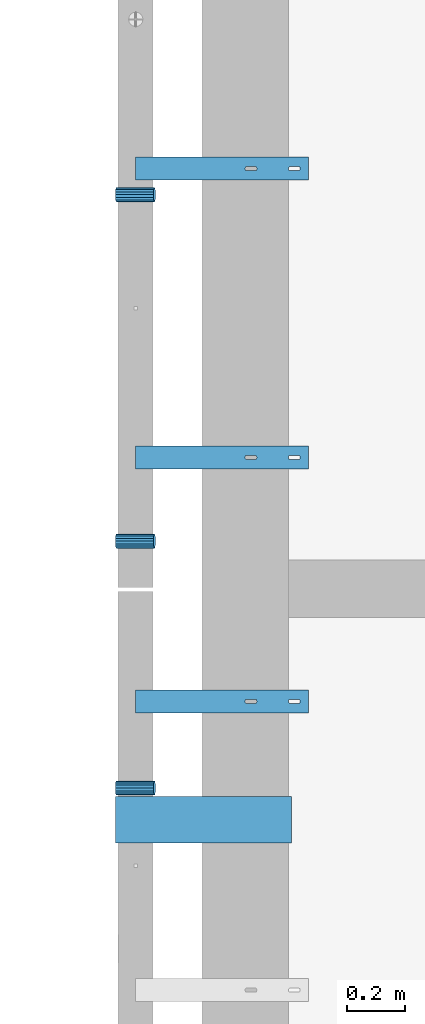
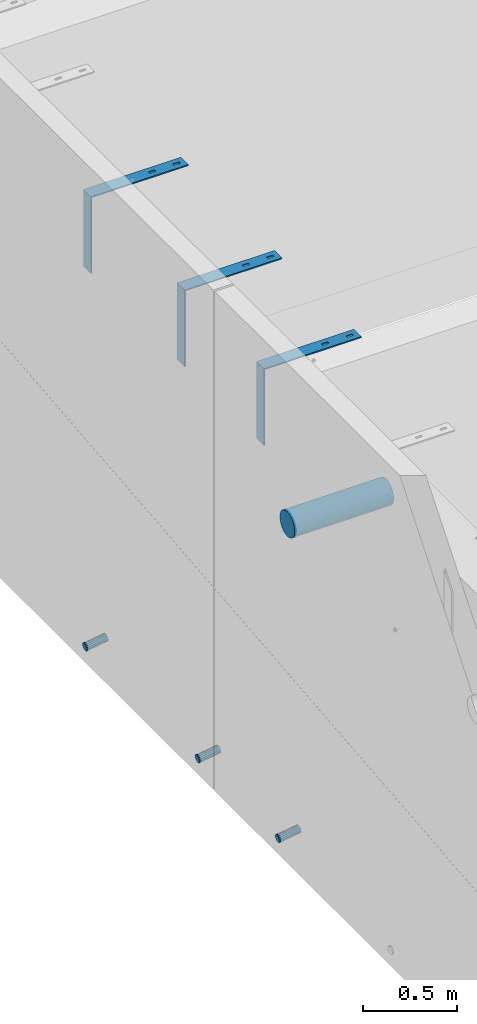
# One storey, part 98 of 264: 7 beams, 9 elements without a shape of their own.
"""IFC2X3 building model written with IfcOpenShell, lengths in millimetres."""

from ifc_helpers import new_model, si_unit, frame, origin_with_axes, place, context, subcontext, project, spatial, faceted_brep, material, type_object, element, aggregate, save


model = new_model("IFC2X3")

# Units and contexts
model_context = context("Model", 3, precision=1e-05, world=origin_with_axes())
body_context = subcontext(model_context, "Body", "Model", "MODEL_VIEW")
ifc_project = project(units=[si_unit("LENGTHUNIT", "METRE", prefix="MILLI"), si_unit("AREAUNIT", "SQUARE_METRE"), si_unit("VOLUMEUNIT", "CUBIC_METRE"), si_unit("MASSUNIT", "GRAM", prefix="KILO"), si_unit("TIMEUNIT", "SECOND"), si_unit("PLANEANGLEUNIT", "RADIAN"), si_unit("SOLIDANGLEUNIT", "STERADIAN"), si_unit("THERMODYNAMICTEMPERATUREUNIT", "DEGREE_CELSIUS"), si_unit("LUMINOUSINTENSITYUNIT", "LUMEN")], contexts=[model_context])

# Site, building, storey
site_placement = place(None, origin_with_axes())
site = spatial("IfcSite", under=ifc_project, at=site_placement, CompositionType="ELEMENT")
building_placement = place(site_placement, origin_with_axes())
building = spatial("IfcBuilding", under=site, at=building_placement, CompositionType="ELEMENT")
storey_placement = place(building_placement, origin_with_axes())
storey = spatial("IfcBuildingStorey", under=building, at=storey_placement, Name="K", CompositionType="ELEMENT", Elevation=0.0)

# Assemblies, beams
assembly_1_placement = place(storey_placement, origin_with_axes())
assembly_1 = element("IfcElementAssembly", 1, at=assembly_1_placement, inside=storey, AssemblyPlace="NOTDEFINED", PredefinedType="REINFORCEMENT_UNIT")
assembly_2_placement = place(assembly_1_placement, origin_with_axes())
assembly_2 = element("IfcElementAssembly", 2, at=assembly_2_placement, Name="Steel Assembly", AssemblyPlace="NOTDEFINED", PredefinedType="NOTDEFINED")
ifc_material_1 = material()
beam_type_1 = type_object("IfcBeamType", Name="D50", PredefinedType="NOTDEFINED")
beam_1_placement = place(assembly_2_placement, frame((7685.611109453, 18344.9999997536, 78614.7172983598), z_axis=(0.0, -1.0, 0.0), x_axis=(-0.988691934499859, -5.59999884149448e-08, -0.149960857075848)))
beam_1 = element("IfcBeam", 3, at=beam_1_placement, type_object=beam_type_1, material=ifc_material_1, ObjectType="D50", context=body_context, shape_type="Brep", body=[
    faceted_brep([(0.0, -25.0, 0.0), (-3.63797880709171e-12, -23.0969883127837, -9.56708580912891), (133.368135763521, -23.0969883127691, -9.56708580912709), (133.368135766923, -24.9999999999854, 1.81898940354586e-12), (-3.63797880709171e-12, -17.6776695296576, -17.6776695296649), (133.36813576064, -17.6776695296576, -17.677669529663), (-1.09139364212751e-11, -9.56708580913255, -23.0969883127837), (133.368135758712, -9.567085809118, -23.0969883127818), (-1.09139364212751e-11, 0.0, -25.0), (133.368135758034, 0.0, -25.0), (-1.09139364212751e-11, 9.56708580913255, -23.0969883127837), (133.36813575871, 9.56708580913255, -23.0969883127837), (-3.63797880709171e-12, 17.6776695296576, -17.6776695296649), (133.36813576064, 17.6776695296721, -17.677669529663), (-3.63797880709171e-12, 23.0969883127837, -9.56708580912891), (133.36813576352, 23.0969883127982, -9.56708580912709), (0.0, 25.0, 0.0), (133.368135766925, 25.0000000000146, -1.81898940354586e-12), (7.27595761418343e-12, 23.0969883127837, 9.56708580912891), (133.368135770323, 23.0969883127837, 9.56708580912709), (7.27595761418343e-12, 17.6776695296576, 17.6776695296649), (133.368135773204, 17.6776695296721, 17.6776695296649), (1.45519152283669e-11, 9.56708580913255, 23.0969883127837), (133.368135775132, 9.5670858091471, 23.0969883127837), (1.09139364212751e-11, 0.0, 25.0), (133.368135775807, 1.45519152283669e-11, 25.0), (1.45519152283669e-11, -9.56708580913255, 23.0969883127837), (133.368135775134, -9.56708580910345, 23.0969883127837), (7.27595761418343e-12, -17.6776695296576, 17.6776695296649), (133.368135773204, -17.6776695296721, 17.6776695296649), (7.27595761418343e-12, -23.0969883127837, 9.56708580912891), (133.368135770321, -23.0969883127691, 9.56708580912709)], [[[0, 1, 2, 3]], [[1, 4, 5, 2]], [[4, 6, 7, 5]], [[6, 8, 9, 7]], [[8, 10, 11, 9]], [[10, 12, 13, 11]], [[12, 14, 15, 13]], [[14, 16, 17, 15]], [[16, 18, 19, 17]], [[18, 20, 21, 19]], [[20, 22, 23, 21]], [[22, 24, 25, 23]], [[24, 26, 27, 25]], [[26, 28, 29, 27]], [[28, 30, 31, 29]], [[30, 0, 3, 31]], [[5, 7, 9, 11, 13, 15, 17, 19, 21, 23, 25, 27, 29, 31, 3, 2]], [[30, 28, 26, 24, 22, 20, 18, 16, 14, 12, 10, 8, 6, 4, 1, 0]]]),
])
aggregate(assembly_2, [beam_1])
assembly_3_placement = place(assembly_1_placement, origin_with_axes())
assembly_3 = element("IfcElementAssembly", 4, at=assembly_3_placement, Name="Steel Assembly", AssemblyPlace="NOTDEFINED", PredefinedType="NOTDEFINED")
beam_2_placement = place(assembly_3_placement, frame((7685.611109453, 17144.9999997536, 78614.7172983598), z_axis=(0.0, -1.0, 0.0), x_axis=(-0.988691934499859, -5.59999884149448e-08, -0.149960857075848)))
beam_2 = element("IfcBeam", 5, at=beam_2_placement, type_object=beam_type_1, material=ifc_material_1, ObjectType="D50", context=body_context, shape_type="Brep", body=[
    faceted_brep([(0.0, -25.0, 0.0), (-3.63797880709171e-12, -23.0969883127837, -9.56708580912891), (133.368135763521, -23.0969883127691, -9.56708580912709), (133.368135766923, -24.9999999999854, 1.81898940354586e-12), (-3.63797880709171e-12, -17.6776695296576, -17.6776695296649), (133.36813576064, -17.6776695296576, -17.677669529663), (-1.09139364212751e-11, -9.56708580913255, -23.0969883127837), (133.368135758712, -9.567085809118, -23.0969883127818), (-1.09139364212751e-11, 0.0, -25.0), (133.368135758034, 0.0, -25.0), (-1.09139364212751e-11, 9.56708580913255, -23.0969883127837), (133.36813575871, 9.56708580913255, -23.0969883127837), (-3.63797880709171e-12, 17.6776695296576, -17.6776695296649), (133.36813576064, 17.6776695296721, -17.677669529663), (-3.63797880709171e-12, 23.0969883127837, -9.56708580912891), (133.36813576352, 23.0969883127982, -9.56708580912709), (0.0, 25.0, 0.0), (133.368135766925, 25.0000000000146, -1.81898940354586e-12), (7.27595761418343e-12, 23.0969883127837, 9.56708580912891), (133.368135770323, 23.0969883127837, 9.56708580912709), (7.27595761418343e-12, 17.6776695296576, 17.6776695296649), (133.368135773204, 17.6776695296721, 17.6776695296649), (1.45519152283669e-11, 9.56708580913255, 23.0969883127837), (133.368135775132, 9.5670858091471, 23.0969883127837), (1.09139364212751e-11, 0.0, 25.0), (133.368135775807, 1.45519152283669e-11, 25.0), (1.45519152283669e-11, -9.56708580913255, 23.0969883127837), (133.368135775134, -9.56708580910345, 23.0969883127837), (7.27595761418343e-12, -17.6776695296576, 17.6776695296649), (133.368135773204, -17.6776695296721, 17.6776695296649), (7.27595761418343e-12, -23.0969883127837, 9.56708580912891), (133.368135770321, -23.0969883127691, 9.56708580912709)], [[[0, 1, 2, 3]], [[1, 4, 5, 2]], [[4, 6, 7, 5]], [[6, 8, 9, 7]], [[8, 10, 11, 9]], [[10, 12, 13, 11]], [[12, 14, 15, 13]], [[14, 16, 17, 15]], [[16, 18, 19, 17]], [[18, 20, 21, 19]], [[20, 22, 23, 21]], [[22, 24, 25, 23]], [[24, 26, 27, 25]], [[26, 28, 29, 27]], [[28, 30, 31, 29]], [[30, 0, 3, 31]], [[5, 7, 9, 11, 13, 15, 17, 19, 21, 23, 25, 27, 29, 31, 3, 2]], [[30, 28, 26, 24, 22, 20, 18, 16, 14, 12, 10, 8, 6, 4, 1, 0]]]),
])
aggregate(assembly_3, [beam_2])

# Assemblies, beam
assembly_4_placement = place(storey_placement, origin_with_axes())
assembly_4 = element("IfcElementAssembly", 6, at=assembly_4_placement, inside=storey, AssemblyPlace="NOTDEFINED", PredefinedType="REINFORCEMENT_UNIT")
assembly_5_placement = place(assembly_4_placement, origin_with_axes())
assembly_5 = element("IfcElementAssembly", 7, at=assembly_5_placement, Name="Steel Assembly", AssemblyPlace="NOTDEFINED", PredefinedType="NOTDEFINED")
beam_3_placement = place(assembly_5_placement, frame((7685.611109453, 16289.9999997536, 78614.7172983598), z_axis=(0.0, -1.0, 0.0), x_axis=(-0.988691934499859, -5.59999884149448e-08, -0.149960857075848)))
beam_3 = element("IfcBeam", 8, at=beam_3_placement, type_object=beam_type_1, material=ifc_material_1, ObjectType="D50", context=body_context, shape_type="Brep", body=[
    faceted_brep([(0.0, -25.0, 0.0), (-3.63797880709171e-12, -23.0969883127837, -9.56708580912891), (133.368135763521, -23.0969883127691, -9.56708580912709), (133.368135766923, -24.9999999999854, 1.81898940354586e-12), (-3.63797880709171e-12, -17.6776695296576, -17.6776695296649), (133.36813576064, -17.6776695296576, -17.677669529663), (-1.09139364212751e-11, -9.56708580913255, -23.0969883127837), (133.368135758712, -9.567085809118, -23.0969883127818), (-1.09139364212751e-11, 0.0, -25.0), (133.368135758034, 0.0, -25.0), (-1.09139364212751e-11, 9.56708580913255, -23.0969883127837), (133.36813575871, 9.56708580913255, -23.0969883127837), (-3.63797880709171e-12, 17.6776695296576, -17.6776695296649), (133.36813576064, 17.6776695296721, -17.677669529663), (-3.63797880709171e-12, 23.0969883127837, -9.56708580912891), (133.36813576352, 23.0969883127982, -9.56708580912709), (0.0, 25.0, 0.0), (133.368135766925, 25.0000000000146, -1.81898940354586e-12), (7.27595761418343e-12, 23.0969883127837, 9.56708580912891), (133.368135770323, 23.0969883127837, 9.56708580912709), (7.27595761418343e-12, 17.6776695296576, 17.6776695296649), (133.368135773204, 17.6776695296721, 17.6776695296649), (1.45519152283669e-11, 9.56708580913255, 23.0969883127837), (133.368135775132, 9.5670858091471, 23.0969883127837), (1.09139364212751e-11, 0.0, 25.0), (133.368135775807, 1.45519152283669e-11, 25.0), (1.45519152283669e-11, -9.56708580913255, 23.0969883127837), (133.368135775134, -9.56708580910345, 23.0969883127837), (7.27595761418343e-12, -17.6776695296576, 17.6776695296649), (133.368135773204, -17.6776695296721, 17.6776695296649), (7.27595761418343e-12, -23.0969883127837, 9.56708580912891), (133.368135770321, -23.0969883127691, 9.56708580912709)], [[[0, 1, 2, 3]], [[1, 4, 5, 2]], [[4, 6, 7, 5]], [[6, 8, 9, 7]], [[8, 10, 11, 9]], [[10, 12, 13, 11]], [[12, 14, 15, 13]], [[14, 16, 17, 15]], [[16, 18, 19, 17]], [[18, 20, 21, 19]], [[20, 22, 23, 21]], [[22, 24, 25, 23]], [[24, 26, 27, 25]], [[26, 28, 29, 27]], [[28, 30, 31, 29]], [[30, 0, 3, 31]], [[5, 7, 9, 11, 13, 15, 17, 19, 21, 23, 25, 27, 29, 31, 3, 2]], [[30, 28, 26, 24, 22, 20, 18, 16, 14, 12, 10, 8, 6, 4, 1, 0]]]),
])
aggregate(assembly_5, [beam_3])

# Assembly, beam
assembly_6_placement = place(assembly_1_placement, origin_with_axes())
assembly_6 = element("IfcElementAssembly", 9, at=assembly_6_placement, Name="Steel Assembly", AssemblyPlace="NOTDEFINED", PredefinedType="RIGID_FRAME")
ifc_material_2 = material(Name="STEEL/1.4301")
beam_type_2 = type_object("IfcBeamType", PredefinedType="NOTDEFINED")
beam_4_placement = place(assembly_6_placement, frame((7920.0, 18395.0, 81220.0), z_axis=(1.0, 0.0, 0.0), x_axis=(0.0, 1.0, 0.0)))
beam_4 = element("IfcBeam", 10, at=beam_4_placement, type_object=beam_type_2, material=ifc_material_2, Name="RST", context=body_context, shape_type="Brep", body=[
    faceted_brep([(41.9999999999854, 250.0, 119.999999999996), (41.9999999999854, 242.0, 119.999999999996), (37.9999999999854, 242.0, 119.999999999996), (37.9999999999854, 250.0, 119.999999999996), (36.4549150281109, 242.0, 119.755282581471), (36.4549150281109, 250.0, 119.755282581471), (35.0610737385232, 242.0, 119.045084971873), (35.0610737385232, 250.0, 119.045084971873), (33.9549150281109, 242.0, 117.93892626146), (33.9549150281109, 250.0, 117.93892626146), (33.244717418509, 242.0, 116.545084971873), (33.244717418509, 250.0, 116.545084971873), (32.9999999999854, 242.0, 114.999999999996), (32.9999999999854, 250.0, 114.999999999996), (32.9999999999854, 242.0, 84.9999999999964), (32.9999999999854, 250.0, 84.9999999999964), (33.244717418509, 242.0, 83.4549150281237), (33.244717418509, 250.0, 83.4549150281237), (33.9549150281109, 242.0, 82.0610737385359), (33.9549150281109, 250.0, 82.0610737385359), (35.0610737385232, 242.0, 80.9549150281237), (35.0610737385232, 250.0, 80.9549150281237), (36.4549150281109, 242.0, 80.2447174185218), (36.4549150281109, 250.0, 80.2447174185218), (37.9999999999854, 242.0, 79.9999999999964), (37.9999999999854, 250.0, 79.9999999999964), (41.9999999999854, 242.0, 79.9999999999964), (41.9999999999854, 250.0, 79.9999999999964), (43.54508497186, 242.0, 80.2447174185218), (43.54508497186, 250.0, 80.2447174185218), (44.9389262614477, 242.0, 80.9549150281237), (44.9389262614477, 250.0, 80.9549150281237), (46.04508497186, 242.0, 82.0610737385359), (46.04508497186, 250.0, 82.0610737385359), (46.7552825814619, 242.0, 83.4549150281237), (46.7552825814619, 250.0, 83.4549150281237), (46.9999999999854, 242.0, 84.9999999999964), (46.9999999999854, 250.0, 84.9999999999964), (46.9999999999854, 242.0, 114.999999999996), (46.9999999999854, 250.0, 114.999999999996), (46.7552825814619, 242.0, 116.545084971873), (46.7552825814619, 250.0, 116.545084971873), (46.04508497186, 242.0, 117.93892626146), (46.04508497186, 250.0, 117.93892626146), (44.9389262614477, 242.0, 119.045084971873), (44.9389262614477, 250.0, 119.045084971873), (43.54508497186, 242.0, 119.755282581471), (43.54508497186, 250.0, 119.755282581471), (0.0, -250.0, -292.0), (0.0, -250.0, -300.0), (80.0, -250.0, -300.0), (80.0, -250.0, -292.0), (0.0, 242.0, -292.0), (80.0, 242.0, -292.0), (0.0, 250.0, 300.0), (0.0, 242.0, 300.0), (80.0, 242.0, 300.0), (80.0, 250.0, 300.0), (0.0, 250.0, -300.0), (80.0, 250.0, -300.0), (46.9999999999854, 250.0, 264.999999999996), (46.7552825814619, 250.0, 266.545084971873), (46.04508497186, 250.0, 267.93892626146), (44.9389262614477, 250.0, 269.045084971873), (43.54508497186, 250.0, 269.755282581471), (41.9999999999854, 250.0, 269.999999999996), (37.9999999999854, 250.0, 269.999999999996), (36.4549150281109, 250.0, 269.755282581471), (35.0610737385232, 250.0, 269.045084971873), (33.9549150281109, 250.0, 267.93892626146), (33.244717418509, 250.0, 266.545084971873), (32.9999999999854, 250.0, 264.999999999996), (32.9999999999854, 250.0, 234.999999999996), (33.244717418509, 250.0, 233.454915028124), (33.9549150281109, 250.0, 232.061073738536), (35.0610737385232, 250.0, 230.954915028124), (36.4549150281109, 250.0, 230.244717418522), (37.9999999999854, 250.0, 229.999999999996), (41.9999999999854, 250.0, 229.999999999996), (43.54508497186, 250.0, 230.244717418522), (44.9389262614477, 250.0, 230.954915028124), (46.04508497186, 250.0, 232.061073738536), (46.7552825814619, 250.0, 233.454915028124), (46.9999999999854, 250.0, 234.999999999996), (46.04508497186, 242.0, 267.93892626146), (44.9389262614477, 242.0, 269.045084971873), (46.7552825814619, 242.0, 266.545084971873), (46.9999999999854, 242.0, 264.999999999996), (46.9999999999854, 242.0, 234.999999999996), (46.7552825814619, 242.0, 233.454915028124), (46.04508497186, 242.0, 232.061073738536), (44.9389262614477, 242.0, 230.954915028124), (43.54508497186, 242.0, 230.244717418522), (41.9999999999854, 242.0, 229.999999999996), (37.9999999999854, 242.0, 229.999999999996), (36.4549150281109, 242.0, 230.244717418522), (35.0610737385232, 242.0, 230.954915028124), (33.9549150281109, 242.0, 232.061073738536), (33.244717418509, 242.0, 233.454915028124), (32.9999999999854, 242.0, 234.999999999996), (32.9999999999854, 242.0, 264.999999999996), (33.244717418509, 242.0, 266.545084971873), (33.9549150281109, 242.0, 267.93892626146), (35.0610737385232, 242.0, 269.045084971873), (36.4549150281109, 242.0, 269.755282581471), (37.9999999999854, 242.0, 269.999999999996), (41.9999999999854, 242.0, 269.999999999996), (43.54508497186, 242.0, 269.755282581471)], [[[0, 1, 2, 3]], [[3, 2, 4, 5]], [[5, 4, 6, 7]], [[7, 6, 8, 9]], [[9, 8, 10, 11]], [[11, 10, 12, 13]], [[13, 12, 14, 15]], [[15, 14, 16, 17]], [[17, 16, 18, 19]], [[19, 18, 20, 21]], [[21, 20, 22, 23]], [[23, 22, 24, 25]], [[25, 24, 26, 27]], [[27, 26, 28, 29]], [[29, 28, 30, 31]], [[31, 30, 32, 33]], [[33, 32, 34, 35]], [[35, 34, 36, 37]], [[37, 36, 38, 39]], [[39, 38, 40, 41]], [[41, 40, 42, 43]], [[43, 42, 44, 45]], [[45, 44, 46, 47]], [[47, 46, 1, 0]], [[48, 49, 50, 51]], [[52, 48, 51, 53]], [[54, 55, 56, 57]], [[49, 48, 52, 55, 54, 58]], [[49, 58, 59, 50]], [[56, 53, 51, 50, 59, 57]], [[58, 54, 57, 59], [39, 41, 43, 45, 47, 0, 3, 5, 7, 9, 11, 13, 15, 17, 19, 21, 23, 25, 27, 29, 31, 33, 35, 37], [60, 61, 62, 63, 64, 65, 66, 67, 68, 69, 70, 71, 72, 73, 74, 75, 76, 77, 78, 79, 80, 81, 82, 83]], [[62, 84, 85, 63]], [[61, 86, 84, 62]], [[60, 87, 86, 61]], [[83, 88, 87, 60]], [[82, 89, 88, 83]], [[81, 90, 89, 82]], [[80, 91, 90, 81]], [[79, 92, 91, 80]], [[78, 93, 92, 79]], [[77, 94, 93, 78]], [[76, 95, 94, 77]], [[75, 96, 95, 76]], [[74, 97, 96, 75]], [[73, 98, 97, 74]], [[72, 99, 98, 73]], [[71, 100, 99, 72]], [[70, 101, 100, 71]], [[69, 102, 101, 70]], [[68, 103, 102, 69]], [[67, 104, 103, 68]], [[66, 105, 104, 67]], [[65, 106, 105, 66]], [[64, 107, 106, 65]], [[63, 85, 107, 64]], [[55, 52, 53, 56], [30, 28, 26, 24, 22, 20, 18, 16, 14, 12, 10, 8, 6, 4, 2, 1, 46, 44, 42, 40, 38, 36, 34, 32], [91, 92, 93, 94, 95, 96, 97, 98, 99, 100, 101, 102, 103, 104, 105, 106, 107, 85, 84, 86, 87, 88, 89, 90]]]),
])
aggregate(assembly_6, [beam_4])

# Assembly
assembly_7_placement = place(assembly_1_placement, origin_with_axes())
assembly_7 = element("IfcElementAssembly", 11, at=assembly_7_placement, Name="Steel Assembly", AssemblyPlace="NOTDEFINED", PredefinedType="RIGID_FRAME")

aggregate(assembly_1, [assembly_6, assembly_7, assembly_2, assembly_3])

# Beam
beam_5_placement = place(assembly_7_placement, frame((7920.0, 17395.0, 81220.0), z_axis=(1.0, 0.0, 0.0), x_axis=(0.0, 1.0, 0.0)))
beam_5 = element("IfcBeam", 12, at=beam_5_placement, type_object=beam_type_2, material=ifc_material_2, Name="RST", context=body_context, shape_type="Brep", body=[
    faceted_brep([(41.9999999999854, 250.0, 119.999999999996), (41.9999999999854, 242.0, 119.999999999996), (37.9999999999854, 242.0, 119.999999999996), (37.9999999999854, 250.0, 119.999999999996), (36.4549150281109, 242.0, 119.755282581471), (36.4549150281109, 250.0, 119.755282581471), (35.0610737385232, 242.0, 119.045084971873), (35.0610737385232, 250.0, 119.045084971873), (33.9549150281109, 242.0, 117.93892626146), (33.9549150281109, 250.0, 117.93892626146), (33.244717418509, 242.0, 116.545084971873), (33.244717418509, 250.0, 116.545084971873), (32.9999999999854, 242.0, 114.999999999996), (32.9999999999854, 250.0, 114.999999999996), (32.9999999999854, 242.0, 84.9999999999964), (32.9999999999854, 250.0, 84.9999999999964), (33.244717418509, 242.0, 83.4549150281237), (33.244717418509, 250.0, 83.4549150281237), (33.9549150281109, 242.0, 82.0610737385359), (33.9549150281109, 250.0, 82.0610737385359), (35.0610737385232, 242.0, 80.9549150281237), (35.0610737385232, 250.0, 80.9549150281237), (36.4549150281109, 242.0, 80.2447174185218), (36.4549150281109, 250.0, 80.2447174185218), (37.9999999999854, 242.0, 79.9999999999964), (37.9999999999854, 250.0, 79.9999999999964), (41.9999999999854, 242.0, 79.9999999999964), (41.9999999999854, 250.0, 79.9999999999964), (43.54508497186, 242.0, 80.2447174185218), (43.54508497186, 250.0, 80.2447174185218), (44.9389262614477, 242.0, 80.9549150281237), (44.9389262614477, 250.0, 80.9549150281237), (46.04508497186, 242.0, 82.0610737385359), (46.04508497186, 250.0, 82.0610737385359), (46.7552825814619, 242.0, 83.4549150281237), (46.7552825814619, 250.0, 83.4549150281237), (46.9999999999854, 242.0, 84.9999999999964), (46.9999999999854, 250.0, 84.9999999999964), (46.9999999999854, 242.0, 114.999999999996), (46.9999999999854, 250.0, 114.999999999996), (46.7552825814619, 242.0, 116.545084971873), (46.7552825814619, 250.0, 116.545084971873), (46.04508497186, 242.0, 117.93892626146), (46.04508497186, 250.0, 117.93892626146), (44.9389262614477, 242.0, 119.045084971873), (44.9389262614477, 250.0, 119.045084971873), (43.54508497186, 242.0, 119.755282581471), (43.54508497186, 250.0, 119.755282581471), (0.0, -250.0, -292.0), (0.0, -250.0, -300.0), (80.0, -250.0, -300.0), (80.0, -250.0, -292.0), (0.0, 242.0, -292.0), (80.0, 242.0, -292.0), (0.0, 250.0, 300.0), (0.0, 242.0, 300.0), (80.0, 242.0, 300.0), (80.0, 250.0, 300.0), (0.0, 250.0, -300.0), (80.0, 250.0, -300.0), (46.9999999999854, 250.0, 264.999999999996), (46.7552825814619, 250.0, 266.545084971873), (46.04508497186, 250.0, 267.93892626146), (44.9389262614477, 250.0, 269.045084971873), (43.54508497186, 250.0, 269.755282581471), (41.9999999999854, 250.0, 269.999999999996), (37.9999999999854, 250.0, 269.999999999996), (36.4549150281109, 250.0, 269.755282581471), (35.0610737385232, 250.0, 269.045084971873), (33.9549150281109, 250.0, 267.93892626146), (33.244717418509, 250.0, 266.545084971873), (32.9999999999854, 250.0, 264.999999999996), (32.9999999999854, 250.0, 234.999999999996), (33.244717418509, 250.0, 233.454915028124), (33.9549150281109, 250.0, 232.061073738536), (35.0610737385232, 250.0, 230.954915028124), (36.4549150281109, 250.0, 230.244717418522), (37.9999999999854, 250.0, 229.999999999996), (41.9999999999854, 250.0, 229.999999999996), (43.54508497186, 250.0, 230.244717418522), (44.9389262614477, 250.0, 230.954915028124), (46.04508497186, 250.0, 232.061073738536), (46.7552825814619, 250.0, 233.454915028124), (46.9999999999854, 250.0, 234.999999999996), (46.04508497186, 242.0, 267.93892626146), (44.9389262614477, 242.0, 269.045084971873), (46.7552825814619, 242.0, 266.545084971873), (46.9999999999854, 242.0, 264.999999999996), (46.9999999999854, 242.0, 234.999999999996), (46.7552825814619, 242.0, 233.454915028124), (46.04508497186, 242.0, 232.061073738536), (44.9389262614477, 242.0, 230.954915028124), (43.54508497186, 242.0, 230.244717418522), (41.9999999999854, 242.0, 229.999999999996), (37.9999999999854, 242.0, 229.999999999996), (36.4549150281109, 242.0, 230.244717418522), (35.0610737385232, 242.0, 230.954915028124), (33.9549150281109, 242.0, 232.061073738536), (33.244717418509, 242.0, 233.454915028124), (32.9999999999854, 242.0, 234.999999999996), (32.9999999999854, 242.0, 264.999999999996), (33.244717418509, 242.0, 266.545084971873), (33.9549150281109, 242.0, 267.93892626146), (35.0610737385232, 242.0, 269.045084971873), (36.4549150281109, 242.0, 269.755282581471), (37.9999999999854, 242.0, 269.999999999996), (41.9999999999854, 242.0, 269.999999999996), (43.54508497186, 242.0, 269.755282581471)], [[[0, 1, 2, 3]], [[3, 2, 4, 5]], [[5, 4, 6, 7]], [[7, 6, 8, 9]], [[9, 8, 10, 11]], [[11, 10, 12, 13]], [[13, 12, 14, 15]], [[15, 14, 16, 17]], [[17, 16, 18, 19]], [[19, 18, 20, 21]], [[21, 20, 22, 23]], [[23, 22, 24, 25]], [[25, 24, 26, 27]], [[27, 26, 28, 29]], [[29, 28, 30, 31]], [[31, 30, 32, 33]], [[33, 32, 34, 35]], [[35, 34, 36, 37]], [[37, 36, 38, 39]], [[39, 38, 40, 41]], [[41, 40, 42, 43]], [[43, 42, 44, 45]], [[45, 44, 46, 47]], [[47, 46, 1, 0]], [[48, 49, 50, 51]], [[52, 48, 51, 53]], [[54, 55, 56, 57]], [[49, 48, 52, 55, 54, 58]], [[49, 58, 59, 50]], [[56, 53, 51, 50, 59, 57]], [[58, 54, 57, 59], [39, 41, 43, 45, 47, 0, 3, 5, 7, 9, 11, 13, 15, 17, 19, 21, 23, 25, 27, 29, 31, 33, 35, 37], [60, 61, 62, 63, 64, 65, 66, 67, 68, 69, 70, 71, 72, 73, 74, 75, 76, 77, 78, 79, 80, 81, 82, 83]], [[62, 84, 85, 63]], [[61, 86, 84, 62]], [[60, 87, 86, 61]], [[83, 88, 87, 60]], [[82, 89, 88, 83]], [[81, 90, 89, 82]], [[80, 91, 90, 81]], [[79, 92, 91, 80]], [[78, 93, 92, 79]], [[77, 94, 93, 78]], [[76, 95, 94, 77]], [[75, 96, 95, 76]], [[74, 97, 96, 75]], [[73, 98, 97, 74]], [[72, 99, 98, 73]], [[71, 100, 99, 72]], [[70, 101, 100, 71]], [[69, 102, 101, 70]], [[68, 103, 102, 69]], [[67, 104, 103, 68]], [[66, 105, 104, 67]], [[65, 106, 105, 66]], [[64, 107, 106, 65]], [[63, 85, 107, 64]], [[55, 52, 53, 56], [30, 28, 26, 24, 22, 20, 18, 16, 14, 12, 10, 8, 6, 4, 2, 1, 46, 44, 42, 40, 38, 36, 34, 32], [91, 92, 93, 94, 95, 96, 97, 98, 99, 100, 101, 102, 103, 104, 105, 106, 107, 85, 84, 86, 87, 88, 89, 90]]]),
])

aggregate(assembly_7, [beam_5])

# Assembly
assembly_8_placement = place(assembly_4_placement, origin_with_axes())
assembly_8 = element("IfcElementAssembly", 13, at=assembly_8_placement, Name="Steel Assembly", AssemblyPlace="NOTDEFINED", PredefinedType="RIGID_FRAME")

aggregate(assembly_4, [assembly_8, assembly_5])

# Beam
beam_6_placement = place(assembly_8_placement, frame((7920.0, 16550.0, 81220.0), z_axis=(1.0, 0.0, 0.0), x_axis=(0.0, 1.0, 0.0)))
beam_6 = element("IfcBeam", 14, at=beam_6_placement, type_object=beam_type_2, material=ifc_material_2, Name="RST", context=body_context, shape_type="Brep", body=[
    faceted_brep([(41.9999999999854, 250.0, 119.999999999996), (41.9999999999854, 242.0, 119.999999999996), (37.9999999999854, 242.0, 119.999999999996), (37.9999999999854, 250.0, 119.999999999996), (36.4549150281109, 242.0, 119.755282581471), (36.4549150281109, 250.0, 119.755282581471), (35.0610737385232, 242.0, 119.045084971873), (35.0610737385232, 250.0, 119.045084971873), (33.9549150281109, 242.0, 117.93892626146), (33.9549150281109, 250.0, 117.93892626146), (33.244717418509, 242.0, 116.545084971873), (33.244717418509, 250.0, 116.545084971873), (32.9999999999854, 242.0, 114.999999999996), (32.9999999999854, 250.0, 114.999999999996), (32.9999999999854, 242.0, 84.9999999999964), (32.9999999999854, 250.0, 84.9999999999964), (33.244717418509, 242.0, 83.4549150281237), (33.244717418509, 250.0, 83.4549150281237), (33.9549150281109, 242.0, 82.0610737385359), (33.9549150281109, 250.0, 82.0610737385359), (35.0610737385232, 242.0, 80.9549150281237), (35.0610737385232, 250.0, 80.9549150281237), (36.4549150281109, 242.0, 80.2447174185218), (36.4549150281109, 250.0, 80.2447174185218), (37.9999999999854, 242.0, 79.9999999999964), (37.9999999999854, 250.0, 79.9999999999964), (41.9999999999854, 242.0, 79.9999999999964), (41.9999999999854, 250.0, 79.9999999999964), (43.54508497186, 242.0, 80.2447174185218), (43.54508497186, 250.0, 80.2447174185218), (44.9389262614477, 242.0, 80.9549150281237), (44.9389262614477, 250.0, 80.9549150281237), (46.04508497186, 242.0, 82.0610737385359), (46.04508497186, 250.0, 82.0610737385359), (46.7552825814619, 242.0, 83.4549150281237), (46.7552825814619, 250.0, 83.4549150281237), (46.9999999999854, 242.0, 84.9999999999964), (46.9999999999854, 250.0, 84.9999999999964), (46.9999999999854, 242.0, 114.999999999996), (46.9999999999854, 250.0, 114.999999999996), (46.7552825814619, 242.0, 116.545084971873), (46.7552825814619, 250.0, 116.545084971873), (46.04508497186, 242.0, 117.93892626146), (46.04508497186, 250.0, 117.93892626146), (44.9389262614477, 242.0, 119.045084971873), (44.9389262614477, 250.0, 119.045084971873), (43.54508497186, 242.0, 119.755282581471), (43.54508497186, 250.0, 119.755282581471), (0.0, -250.0, -292.0), (0.0, -250.0, -300.0), (80.0, -250.0, -300.0), (80.0, -250.0, -292.0), (0.0, 242.0, -292.0), (80.0, 242.0, -292.0), (0.0, 250.0, 300.0), (0.0, 242.0, 300.0), (80.0, 242.0, 300.0), (80.0, 250.0, 300.0), (0.0, 250.0, -300.0), (80.0, 250.0, -300.0), (46.9999999999854, 250.0, 264.999999999996), (46.7552825814619, 250.0, 266.545084971873), (46.04508497186, 250.0, 267.93892626146), (44.9389262614477, 250.0, 269.045084971873), (43.54508497186, 250.0, 269.755282581471), (41.9999999999854, 250.0, 269.999999999996), (37.9999999999854, 250.0, 269.999999999996), (36.4549150281109, 250.0, 269.755282581471), (35.0610737385232, 250.0, 269.045084971873), (33.9549150281109, 250.0, 267.93892626146), (33.244717418509, 250.0, 266.545084971873), (32.9999999999854, 250.0, 264.999999999996), (32.9999999999854, 250.0, 234.999999999996), (33.244717418509, 250.0, 233.454915028124), (33.9549150281109, 250.0, 232.061073738536), (35.0610737385232, 250.0, 230.954915028124), (36.4549150281109, 250.0, 230.244717418522), (37.9999999999854, 250.0, 229.999999999996), (41.9999999999854, 250.0, 229.999999999996), (43.54508497186, 250.0, 230.244717418522), (44.9389262614477, 250.0, 230.954915028124), (46.04508497186, 250.0, 232.061073738536), (46.7552825814619, 250.0, 233.454915028124), (46.9999999999854, 250.0, 234.999999999996), (46.04508497186, 242.0, 267.93892626146), (44.9389262614477, 242.0, 269.045084971873), (46.7552825814619, 242.0, 266.545084971873), (46.9999999999854, 242.0, 264.999999999996), (46.9999999999854, 242.0, 234.999999999996), (46.7552825814619, 242.0, 233.454915028124), (46.04508497186, 242.0, 232.061073738536), (44.9389262614477, 242.0, 230.954915028124), (43.54508497186, 242.0, 230.244717418522), (41.9999999999854, 242.0, 229.999999999996), (37.9999999999854, 242.0, 229.999999999996), (36.4549150281109, 242.0, 230.244717418522), (35.0610737385232, 242.0, 230.954915028124), (33.9549150281109, 242.0, 232.061073738536), (33.244717418509, 242.0, 233.454915028124), (32.9999999999854, 242.0, 234.999999999996), (32.9999999999854, 242.0, 264.999999999996), (33.244717418509, 242.0, 266.545084971873), (33.9549150281109, 242.0, 267.93892626146), (35.0610737385232, 242.0, 269.045084971873), (36.4549150281109, 242.0, 269.755282581471), (37.9999999999854, 242.0, 269.999999999996), (41.9999999999854, 242.0, 269.999999999996), (43.54508497186, 242.0, 269.755282581471)], [[[0, 1, 2, 3]], [[3, 2, 4, 5]], [[5, 4, 6, 7]], [[7, 6, 8, 9]], [[9, 8, 10, 11]], [[11, 10, 12, 13]], [[13, 12, 14, 15]], [[15, 14, 16, 17]], [[17, 16, 18, 19]], [[19, 18, 20, 21]], [[21, 20, 22, 23]], [[23, 22, 24, 25]], [[25, 24, 26, 27]], [[27, 26, 28, 29]], [[29, 28, 30, 31]], [[31, 30, 32, 33]], [[33, 32, 34, 35]], [[35, 34, 36, 37]], [[37, 36, 38, 39]], [[39, 38, 40, 41]], [[41, 40, 42, 43]], [[43, 42, 44, 45]], [[45, 44, 46, 47]], [[47, 46, 1, 0]], [[48, 49, 50, 51]], [[52, 48, 51, 53]], [[54, 55, 56, 57]], [[49, 48, 52, 55, 54, 58]], [[49, 58, 59, 50]], [[56, 53, 51, 50, 59, 57]], [[58, 54, 57, 59], [39, 41, 43, 45, 47, 0, 3, 5, 7, 9, 11, 13, 15, 17, 19, 21, 23, 25, 27, 29, 31, 33, 35, 37], [60, 61, 62, 63, 64, 65, 66, 67, 68, 69, 70, 71, 72, 73, 74, 75, 76, 77, 78, 79, 80, 81, 82, 83]], [[62, 84, 85, 63]], [[61, 86, 84, 62]], [[60, 87, 86, 61]], [[83, 88, 87, 60]], [[82, 89, 88, 83]], [[81, 90, 89, 82]], [[80, 91, 90, 81]], [[79, 92, 91, 80]], [[78, 93, 92, 79]], [[77, 94, 93, 78]], [[76, 95, 94, 77]], [[75, 96, 95, 76]], [[74, 97, 96, 75]], [[73, 98, 97, 74]], [[72, 99, 98, 73]], [[71, 100, 99, 72]], [[70, 101, 100, 71]], [[69, 102, 101, 70]], [[68, 103, 102, 69]], [[67, 104, 103, 68]], [[66, 105, 104, 67]], [[65, 106, 105, 66]], [[64, 107, 106, 65]], [[63, 85, 107, 64]], [[55, 52, 53, 56], [30, 28, 26, 24, 22, 20, 18, 16, 14, 12, 10, 8, 6, 4, 2, 1, 46, 44, 42, 40, 38, 36, 34, 32], [91, 92, 93, 94, 95, 96, 97, 98, 99, 100, 101, 102, 103, 104, 105, 106, 107, 85, 84, 86, 87, 88, 89, 90]]]),
])

aggregate(assembly_8, [beam_6])

# Assembly, beam
assembly_9_placement = place(storey_placement, origin_with_axes())
assembly_9 = element("IfcElementAssembly", 15, at=assembly_9_placement, inside=storey, Name="Steel Assembly", AssemblyPlace="NOTDEFINED", PredefinedType="NOTDEFINED")
ifc_material_3 = material()
beam_type_3 = type_object("IfcBeamType", Name="D160", PredefinedType="NOTDEFINED")
beam_7_placement = place(assembly_9_placement, frame((7550.00022739172, 16179.9991592765, 80710.0), z_axis=(0.0, 0.0, 1.0), x_axis=(1.0, 0.0, 0.0)))
beam_7 = element("IfcBeam", 16, at=beam_7_placement, type_object=beam_type_3, material=ifc_material_3, ObjectType="D160", context=body_context, shape_type="Brep", body=[
    faceted_brep([(0.0, -80.0, 0.0), (0.0, -77.2740661031276, -20.7055236082015), (610.000093691564, -77.2740661031257, -20.7055236082088), (610.000093691564, -80.0, 0.0), (0.0, -69.2820323027554, -40.0), (610.000093691564, -69.2820323027554, -40.0), (0.0, -56.5685424949188, -56.5685424949243), (610.000093691564, -56.5685424949243, -56.5685424949188), (0.0, -40.0, -69.2820323027554), (610.000093691564, -40.0, -69.2820323027554), (0.0, -20.7055236082088, -77.2740661031257), (610.000093691564, -20.7055236082015, -77.2740661031276), (0.0, 0.0, -80.0), (610.000093691564, 0.0, -80.0), (0.0, 20.7055236082088, -77.2740661031257), (610.000093691564, 20.7055236082015, -77.2740661031276), (0.0, 40.0, -69.2820323027554), (610.000093691564, 40.0, -69.2820323027554), (0.0, 56.5685424949188, -56.5685424949243), (610.000093691564, 56.5685424949243, -56.5685424949188), (0.0, 69.2820323027554, -40.0), (610.000093691564, 69.2820323027554, -40.0), (0.0, 77.2740661031276, -20.7055236082015), (610.000093691564, 77.2740661031257, -20.7055236082088), (0.0, 80.0, 0.0), (610.000093691564, 80.0, 0.0), (0.0, 77.2740661031276, 20.7055236082015), (610.000093691564, 77.2740661031257, 20.7055236082088), (0.0, 69.2820323027554, 40.0), (610.000093691564, 69.2820323027554, 40.0), (0.0, 56.5685424949188, 56.5685424949243), (610.000093691564, 56.5685424949243, 56.5685424949188), (0.0, 40.0, 69.2820323027554), (610.000093691564, 40.0, 69.2820323027554), (0.0, 20.7055236082088, 77.2740661031257), (610.000093691564, 20.7055236082015, 77.2740661031276), (0.0, 0.0, 80.0), (610.000093691564, 0.0, 80.0), (0.0, -20.7055236082088, 77.2740661031257), (610.000093691564, -20.7055236082015, 77.2740661031276), (0.0, -40.0, 69.2820323027554), (610.000093691564, -40.0, 69.2820323027554), (0.0, -56.5685424949188, 56.5685424949243), (610.000093691564, -56.5685424949243, 56.5685424949188), (0.0, -69.2820323027554, 40.0), (610.000093691564, -69.2820323027554, 40.0), (0.0, -77.2740661031276, 20.7055236082015), (610.000093691564, -77.2740661031257, 20.7055236082088)], [[[0, 1, 2, 3]], [[1, 4, 5, 2]], [[4, 6, 7, 5]], [[6, 8, 9, 7]], [[8, 10, 11, 9]], [[10, 12, 13, 11]], [[12, 14, 15, 13]], [[14, 16, 17, 15]], [[16, 18, 19, 17]], [[18, 20, 21, 19]], [[20, 22, 23, 21]], [[22, 24, 25, 23]], [[24, 26, 27, 25]], [[26, 28, 29, 27]], [[28, 30, 31, 29]], [[30, 32, 33, 31]], [[32, 34, 35, 33]], [[34, 36, 37, 35]], [[36, 38, 39, 37]], [[38, 40, 41, 39]], [[40, 42, 43, 41]], [[42, 44, 45, 43]], [[44, 46, 47, 45]], [[46, 0, 3, 47]], [[5, 7, 9, 11, 13, 15, 17, 19, 21, 23, 25, 27, 29, 31, 33, 35, 37, 39, 41, 43, 45, 47, 3, 2]], [[46, 44, 42, 40, 38, 36, 34, 32, 30, 28, 26, 24, 22, 20, 18, 16, 14, 12, 10, 8, 6, 4, 1, 0]]]),
])
aggregate(assembly_9, [beam_7])

save(model, "model.ifc")
